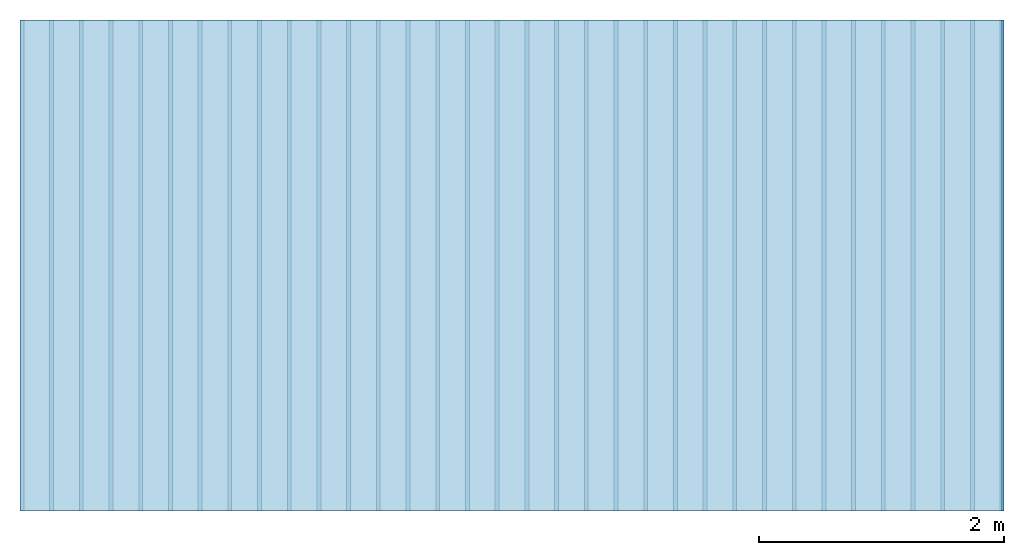
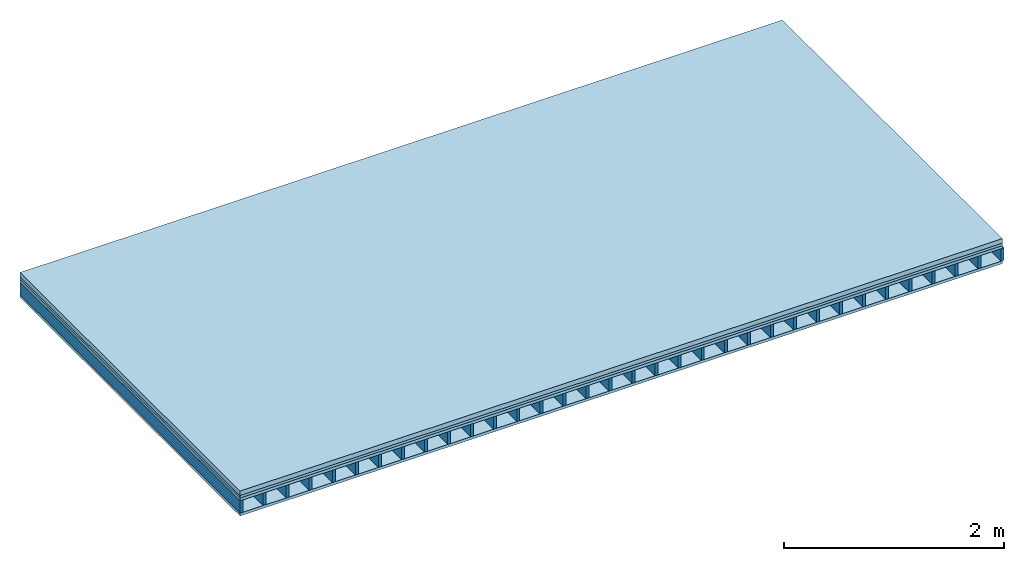
# One storey: 4 plates, 1 member, 1 element without a shape of its own.
"""IFC4 building model written with IfcOpenShell, lengths in metres."""

from ifc_helpers import new_model, si_unit, derived_unit, direction, frame, frame_2d, origin, origin_with_axes, place, context, project, spatial, rectangle, extrude, material, layer, layer_set, type_object, element, aggregate, save


model = new_model("IFC4")

# Units and contexts
plan_context = context("Plan", 3, precision=1e-05, world=origin(), true_north=direction((0.0, 1.0)))
model_context = context("Model", 3, precision=1e-05, world=origin(), true_north=direction((0.0, 1.0)))
ifc_project = project(units=[si_unit("LENGTHUNIT", "METRE"), derived_unit("SOUNDPRESSUREUNIT", [(si_unit("PRESSUREUNIT", "PASCAL", prefix="MICRO"), 0)]), si_unit("ENERGYUNIT", "JOULE", prefix="MEGA"), si_unit("MASSUNIT", "GRAM", prefix="KILO"), derived_unit("THERMALTRANSMITTANCEUNIT", [(si_unit("POWERUNIT", "WATT"), 1), (si_unit("AREAUNIT", "SQUARE_METRE"), -1), (si_unit("THERMODYNAMICTEMPERATUREUNIT", "KELVIN"), -1)]), derived_unit("AREADENSITYUNIT", [(si_unit("MASSUNIT", "GRAM", prefix="KILO"), 1), (si_unit("AREAUNIT", "SQUARE_METRE"), -1)]), derived_unit("USERDEFINED", [(si_unit("ENERGYUNIT", "JOULE", prefix="MEGA"), 1), (si_unit("AREAUNIT", "SQUARE_METRE"), -1)])], contexts=[plan_context, model_context])

# Site, building, storey
site = spatial("IfcSite", under=ifc_project)
building_placement = place(None, origin())
building = spatial("IfcBuilding", under=site, at=building_placement)
storey_placement = place(building_placement, origin())
storey = spatial("IfcBuildingStorey", under=building, at=storey_placement)

# Slab, member, plates
ifc_material_1 = material(Name="Cement screed", Category="04.006")
ifc_layer_1 = layer(ifc_material_1, 0.05, Name="On-material")
ifc_material_2 = material()
ifc_layer_2 = layer(ifc_material_2, 0.027, Name="Impact sound insulation")
ifc_material_3 = material(Name="surface element sheathing above")
ifc_layer_3 = layer(ifc_material_3, 0.031, Name="Sub-floor")
ifc_layer_4 = layer(None, 0.138, Name="Supporting structure")
ifc_material_4 = material(Name="surface element sheathing below")
ifc_layer_5 = layer(ifc_material_4, 0.031, Name="Lower layer 1")
ifc_layer_set = layer_set([ifc_layer_1, ifc_layer_2, ifc_layer_3, ifc_layer_4, ifc_layer_5])
slab_type = type_object("IfcSlabType", Name="A0029", PredefinedType="NOTDEFINED", material=ifc_layer_set)
slab_placement = place(None, frame((0.0, 0.0, 0.0), z_axis=(0.0, 0.0, -1.0), x_axis=(1.0, 0.0, 0.0)))
slab = element("IfcSlab", 1, at=slab_placement, inside=storey, type_object=slab_type, material=ifc_layer_set, Name="Slab #1")
ifc_material_5 = material(Name="surface element LFE")
member_placement = place(slab_placement, origin())
member = element("IfcMember", 2, at=member_placement, material=ifc_material_5, Name="Supporting structure", context=plan_context, shape_type="SweptSolid", body=[
    extrude(rectangle(XDim=0.031, YDim=0.138, at=frame_2d((0.0155, 0.069), x_axis=(1.0, 0.0))), frame((0.0, 4.0, 0.108), z_axis=(0.0, -1.0, 0.0), x_axis=(1.0, 0.0, 0.0)), (0.0, 0.0, 1.0), 4.0),
    extrude(rectangle(XDim=0.031, YDim=0.138, at=frame_2d((0.0155, 0.069), x_axis=(1.0, 0.0))), frame((0.242, 4.0, 0.108), z_axis=(0.0, -1.0, 0.0), x_axis=(1.0, 0.0, 0.0)), (0.0, 0.0, 1.0), 4.0),
    extrude(rectangle(XDim=0.031, YDim=0.138, at=frame_2d((0.0155, 0.069), x_axis=(1.0, 0.0))), frame((0.484, 4.0, 0.108), z_axis=(0.0, -1.0, 0.0), x_axis=(1.0, 0.0, 0.0)), (0.0, 0.0, 1.0), 4.0),
    extrude(rectangle(XDim=0.031, YDim=0.138, at=frame_2d((0.0155, 0.069), x_axis=(1.0, 0.0))), frame((0.726, 4.0, 0.108), z_axis=(0.0, -1.0, 0.0), x_axis=(1.0, 0.0, 0.0)), (0.0, 0.0, 1.0), 4.0),
    extrude(rectangle(XDim=0.031, YDim=0.138, at=frame_2d((0.0155, 0.069), x_axis=(1.0, 0.0))), frame((0.968, 4.0, 0.108), z_axis=(0.0, -1.0, 0.0), x_axis=(1.0, 0.0, 0.0)), (0.0, 0.0, 1.0), 4.0),
    extrude(rectangle(XDim=0.031, YDim=0.138, at=frame_2d((0.0155, 0.069), x_axis=(1.0, 0.0))), frame((1.21, 4.0, 0.108), z_axis=(0.0, -1.0, 0.0), x_axis=(1.0, 0.0, 0.0)), (0.0, 0.0, 1.0), 4.0),
    extrude(rectangle(XDim=0.031, YDim=0.138, at=frame_2d((0.0155, 0.069), x_axis=(1.0, 0.0))), frame((1.452, 4.0, 0.108), z_axis=(0.0, -1.0, 0.0), x_axis=(1.0, 0.0, 0.0)), (0.0, 0.0, 1.0), 4.0),
    extrude(rectangle(XDim=0.031, YDim=0.138, at=frame_2d((0.0155, 0.069), x_axis=(1.0, 0.0))), frame((1.694, 4.0, 0.108), z_axis=(0.0, -1.0, 0.0), x_axis=(1.0, 0.0, 0.0)), (0.0, 0.0, 1.0), 4.0),
    extrude(rectangle(XDim=0.031, YDim=0.138, at=frame_2d((0.0155, 0.069), x_axis=(1.0, 0.0))), frame((1.936, 4.0, 0.108), z_axis=(0.0, -1.0, 0.0), x_axis=(1.0, 0.0, 0.0)), (0.0, 0.0, 1.0), 4.0),
    extrude(rectangle(XDim=0.031, YDim=0.138, at=frame_2d((0.0155, 0.069), x_axis=(1.0, 0.0))), frame((2.178, 4.0, 0.108), z_axis=(0.0, -1.0, 0.0), x_axis=(1.0, 0.0, 0.0)), (0.0, 0.0, 1.0), 4.0),
    extrude(rectangle(XDim=0.031, YDim=0.138, at=frame_2d((0.0155, 0.069), x_axis=(1.0, 0.0))), frame((2.42, 4.0, 0.108), z_axis=(0.0, -1.0, 0.0), x_axis=(1.0, 0.0, 0.0)), (0.0, 0.0, 1.0), 4.0),
    extrude(rectangle(XDim=0.031, YDim=0.138, at=frame_2d((0.0155, 0.069), x_axis=(1.0, 0.0))), frame((2.662, 4.0, 0.108), z_axis=(0.0, -1.0, 0.0), x_axis=(1.0, 0.0, 0.0)), (0.0, 0.0, 1.0), 4.0),
    extrude(rectangle(XDim=0.031, YDim=0.138, at=frame_2d((0.0155, 0.069), x_axis=(1.0, 0.0))), frame((2.904, 4.0, 0.108), z_axis=(0.0, -1.0, 0.0), x_axis=(1.0, 0.0, 0.0)), (0.0, 0.0, 1.0), 4.0),
    extrude(rectangle(XDim=0.031, YDim=0.138, at=frame_2d((0.0155, 0.069), x_axis=(1.0, 0.0))), frame((3.146, 4.0, 0.108), z_axis=(0.0, -1.0, 0.0), x_axis=(1.0, 0.0, 0.0)), (0.0, 0.0, 1.0), 4.0),
    extrude(rectangle(XDim=0.031, YDim=0.138, at=frame_2d((0.0155, 0.069), x_axis=(1.0, 0.0))), frame((3.388, 4.0, 0.108), z_axis=(0.0, -1.0, 0.0), x_axis=(1.0, 0.0, 0.0)), (0.0, 0.0, 1.0), 4.0),
    extrude(rectangle(XDim=0.031, YDim=0.138, at=frame_2d((0.0155, 0.069), x_axis=(1.0, 0.0))), frame((3.63, 4.0, 0.108), z_axis=(0.0, -1.0, 0.0), x_axis=(1.0, 0.0, 0.0)), (0.0, 0.0, 1.0), 4.0),
    extrude(rectangle(XDim=0.031, YDim=0.138, at=frame_2d((0.0155, 0.069), x_axis=(1.0, 0.0))), frame((3.872, 4.0, 0.108), z_axis=(0.0, -1.0, 0.0), x_axis=(1.0, 0.0, 0.0)), (0.0, 0.0, 1.0), 4.0),
    extrude(rectangle(XDim=0.031, YDim=0.138, at=frame_2d((0.0155, 0.069), x_axis=(1.0, 0.0))), frame((4.114, 4.0, 0.108), z_axis=(0.0, -1.0, 0.0), x_axis=(1.0, 0.0, 0.0)), (0.0, 0.0, 1.0), 4.0),
    extrude(rectangle(XDim=0.031, YDim=0.138, at=frame_2d((0.0155, 0.069), x_axis=(1.0, 0.0))), frame((4.356, 4.0, 0.108), z_axis=(0.0, -1.0, 0.0), x_axis=(1.0, 0.0, 0.0)), (0.0, 0.0, 1.0), 4.0),
    extrude(rectangle(XDim=0.031, YDim=0.138, at=frame_2d((0.0155, 0.069), x_axis=(1.0, 0.0))), frame((4.598, 4.0, 0.108), z_axis=(0.0, -1.0, 0.0), x_axis=(1.0, 0.0, 0.0)), (0.0, 0.0, 1.0), 4.0),
    extrude(rectangle(XDim=0.031, YDim=0.138, at=frame_2d((0.0155, 0.069), x_axis=(1.0, 0.0))), frame((4.84, 4.0, 0.108), z_axis=(0.0, -1.0, 0.0), x_axis=(1.0, 0.0, 0.0)), (0.0, 0.0, 1.0), 4.0),
    extrude(rectangle(XDim=0.031, YDim=0.138, at=frame_2d((0.0155, 0.069), x_axis=(1.0, 0.0))), frame((5.082, 4.0, 0.108), z_axis=(0.0, -1.0, 0.0), x_axis=(1.0, 0.0, 0.0)), (0.0, 0.0, 1.0), 4.0),
    extrude(rectangle(XDim=0.031, YDim=0.138, at=frame_2d((0.0155, 0.069), x_axis=(1.0, 0.0))), frame((5.324, 4.0, 0.108), z_axis=(0.0, -1.0, 0.0), x_axis=(1.0, 0.0, 0.0)), (0.0, 0.0, 1.0), 4.0),
    extrude(rectangle(XDim=0.031, YDim=0.138, at=frame_2d((0.0155, 0.069), x_axis=(1.0, 0.0))), frame((5.566, 4.0, 0.108), z_axis=(0.0, -1.0, 0.0), x_axis=(1.0, 0.0, 0.0)), (0.0, 0.0, 1.0), 4.0),
    extrude(rectangle(XDim=0.031, YDim=0.138, at=frame_2d((0.0155, 0.069), x_axis=(1.0, 0.0))), frame((5.808, 4.0, 0.108), z_axis=(0.0, -1.0, 0.0), x_axis=(1.0, 0.0, 0.0)), (0.0, 0.0, 1.0), 4.0),
    extrude(rectangle(XDim=0.031, YDim=0.138, at=frame_2d((0.0155, 0.069), x_axis=(1.0, 0.0))), frame((6.05, 4.0, 0.108), z_axis=(0.0, -1.0, 0.0), x_axis=(1.0, 0.0, 0.0)), (0.0, 0.0, 1.0), 4.0),
    extrude(rectangle(XDim=0.031, YDim=0.138, at=frame_2d((0.0155, 0.069), x_axis=(1.0, 0.0))), frame((6.292, 4.0, 0.108), z_axis=(0.0, -1.0, 0.0), x_axis=(1.0, 0.0, 0.0)), (0.0, 0.0, 1.0), 4.0),
    extrude(rectangle(XDim=0.031, YDim=0.138, at=frame_2d((0.0155, 0.069), x_axis=(1.0, 0.0))), frame((6.534, 4.0, 0.108), z_axis=(0.0, -1.0, 0.0), x_axis=(1.0, 0.0, 0.0)), (0.0, 0.0, 1.0), 4.0),
    extrude(rectangle(XDim=0.031, YDim=0.138, at=frame_2d((0.0155, 0.069), x_axis=(1.0, 0.0))), frame((6.776, 4.0, 0.108), z_axis=(0.0, -1.0, 0.0), x_axis=(1.0, 0.0, 0.0)), (0.0, 0.0, 1.0), 4.0),
    extrude(rectangle(XDim=0.031, YDim=0.138, at=frame_2d((0.0155, 0.069), x_axis=(1.0, 0.0))), frame((7.018, 4.0, 0.108), z_axis=(0.0, -1.0, 0.0), x_axis=(1.0, 0.0, 0.0)), (0.0, 0.0, 1.0), 4.0),
    extrude(rectangle(XDim=0.031, YDim=0.138, at=frame_2d((0.0155, 0.069), x_axis=(1.0, 0.0))), frame((7.26, 4.0, 0.108), z_axis=(0.0, -1.0, 0.0), x_axis=(1.0, 0.0, 0.0)), (0.0, 0.0, 1.0), 4.0),
    extrude(rectangle(XDim=0.031, YDim=0.138, at=frame_2d((0.0155, 0.069), x_axis=(1.0, 0.0))), frame((7.502, 4.0, 0.108), z_axis=(0.0, -1.0, 0.0), x_axis=(1.0, 0.0, 0.0)), (0.0, 0.0, 1.0), 4.0),
    extrude(rectangle(XDim=0.031, YDim=0.138, at=frame_2d((0.0155, 0.069), x_axis=(1.0, 0.0))), frame((7.744, 4.0, 0.108), z_axis=(0.0, -1.0, 0.0), x_axis=(1.0, 0.0, 0.0)), (0.0, 0.0, 1.0), 4.0),
    extrude(rectangle(XDim=0.031, YDim=0.138, at=frame_2d((0.0155, 0.069), x_axis=(1.0, 0.0))), frame((7.986, 4.0, 0.108), z_axis=(0.0, -1.0, 0.0), x_axis=(1.0, 0.0, 0.0)), (0.0, 0.0, 1.0), 4.0),
])
plate_1_placement = place(slab_placement, origin())
plate_1 = element("IfcPlate", 3, at=plate_1_placement, material=ifc_material_1, Name="On-material", context=plan_context, shape_type="SweptSolid", body=[
    extrude(rectangle(XDim=8.0, YDim=4.0, at=frame_2d((4.0, 2.0), x_axis=(1.0, 0.0))), origin_with_axes(), (0.0, 0.0, 1.0), 0.05),
])
plate_2_placement = place(slab_placement, origin())
plate_2 = element("IfcPlate", 4, at=plate_2_placement, material=ifc_material_2, Name="Impact sound insulation", context=plan_context, shape_type="SweptSolid", body=[
    extrude(rectangle(XDim=8.0, YDim=4.0, at=frame_2d((4.0, 2.0), x_axis=(1.0, 0.0))), frame((0.0, 0.0, 0.05), z_axis=(0.0, 0.0, 1.0), x_axis=(1.0, 0.0, 0.0)), (0.0, 0.0, 1.0), 0.027),
])
plate_3_placement = place(slab_placement, origin())
plate_3 = element("IfcPlate", 5, at=plate_3_placement, material=ifc_material_3, Name="Sub-floor", context=plan_context, shape_type="SweptSolid", body=[
    extrude(rectangle(XDim=8.0, YDim=4.0, at=frame_2d((4.0, 2.0), x_axis=(1.0, 0.0))), frame((0.0, 0.0, 0.077), z_axis=(0.0, 0.0, 1.0), x_axis=(1.0, 0.0, 0.0)), (0.0, 0.0, 1.0), 0.031),
])
plate_4_placement = place(slab_placement, origin())
plate_4 = element("IfcPlate", 6, at=plate_4_placement, material=ifc_material_4, Name="Lower layer 1", context=plan_context, shape_type="SweptSolid", body=[
    extrude(rectangle(XDim=8.0, YDim=4.0, at=frame_2d((4.0, 2.0), x_axis=(1.0, 0.0))), frame((0.0, 0.0, 0.246), z_axis=(0.0, 0.0, 1.0), x_axis=(1.0, 0.0, 0.0)), (0.0, 0.0, 1.0), 0.031),
])
aggregate(slab, [plate_1, plate_2, plate_3, member, plate_4])

save(model, "model.ifc")
